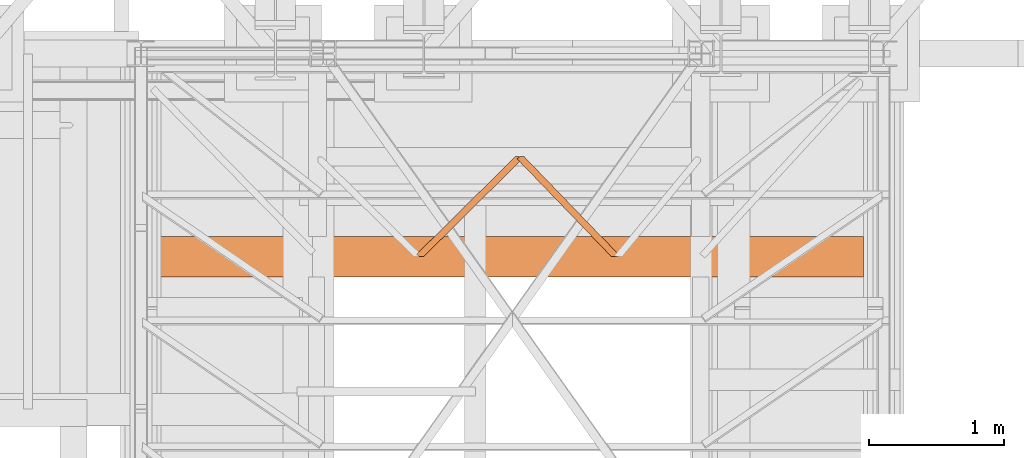
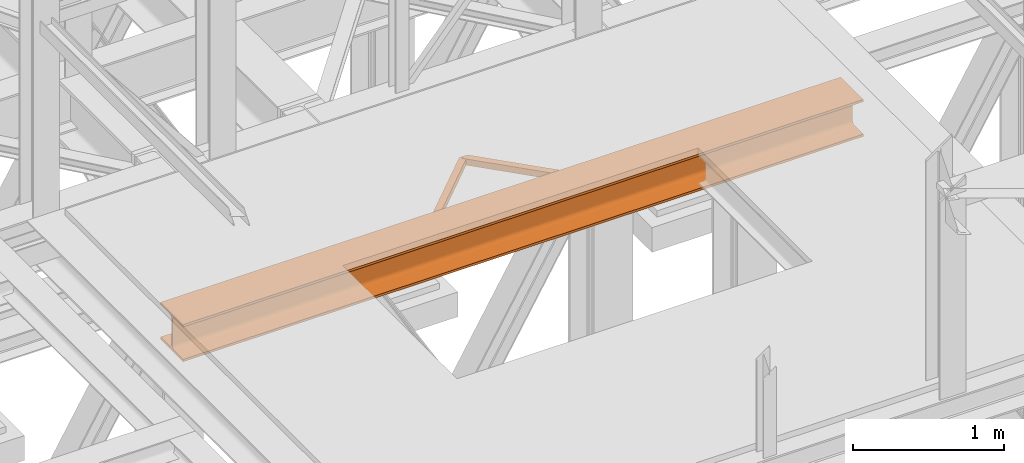
# One storey, part 68 of 208: 3 proxies.
"""IFC2X3 building model written with IfcOpenShell, lengths in millimetres."""

from ifc_helpers import new_model, entity, si_unit, converted_unit, frame, origin, origin_with_axes, place, context, subcontext, project, spatial, faceted_brep, element, save


model = new_model("IFC2X3")

# Units and contexts
model_context = context("Model", 3, precision=1e-05, world=origin())
plan_context = context("Plan", 3, precision=1e-05, world=origin())
body_context = subcontext(model_context, "Body", "Model", "MODEL_VIEW")
ifc_project = project(units=[si_unit("LENGTHUNIT", "METRE", prefix="MILLI"), converted_unit("PLANEANGLEUNIT", "DEGREE", entity("IfcPlaneAngleMeasure", 0.0174532925199433), si_unit("PLANEANGLEUNIT", "RADIAN"), dimensions=[0, 0, 0, 0, 0, 0, 0]), si_unit("AREAUNIT", "SQUARE_METRE"), si_unit("VOLUMEUNIT", "CUBIC_METRE")], contexts=[model_context, plan_context])

# Building, storey
building_placement = place(None, origin())
building = spatial("IfcBuilding", under=ifc_project, at=building_placement, CompositionType="COMPLEX")
storey_placement = place(building_placement, origin_with_axes())
storey = spatial("IfcBuildingStorey", under=building, at=storey_placement, Name="Geschoss", CompositionType="ELEMENT")

# Proxies
proxy_1_placement = place(storey_placement, frame((3238.199636538295, -18763.0743901279, 5124.989999999998), z_axis=(0.0, 0.0, 1.0), x_axis=(1.0, 0.0, 0.0)))
element("IfcBuildingElementProxy", 1, at=proxy_1_placement, inside=storey, context=body_context, shape_type="Brep", body=[
    faceted_brep([(733.6206372988609, 739.8100000473096, 0.01000000000021828), (733.6206372988618, 739.8100000473096, 50.01000000000022), (0.01000000000021828, 13.68593938003687, 50.01000000000022), (0.01000000000021828, 13.68593938003687, 0.01000000000021828), (759.638881951425, 739.8100000473096, 0.01000000000021828), (733.6206372988609, 739.8100000473096, 0.01000000000021828), (0.01000000000021828, 13.68593938003687, 0.01000000000021828), (18.38576148241555, 0.00999999999839929, 0.01000000000021828), (56.46338220809412, 0.00999999999839929, 0.01000000000021828), (784.8981974364888, 721.0110584260037, 0.01000000000021828), (784.8981974364888, 721.0110584260037, 0.01000000000021828), (56.46338220809412, 0.00999999999839929, 0.01000000000021828), (56.46338220809412, 0.00999999999839929, 50.01000000000022), (784.8981974364888, 721.0110584260037, 50.01000000000022), (784.8981974364888, 721.0110584260037, 50.01000000000022), (56.46338220809412, 0.00999999999839929, 50.01000000000022), (18.38576148241555, 0.00999999999839929, 50.01000000000022), (0.01000000000021828, 13.68593938003687, 50.01000000000022), (733.6206372988618, 739.8100000473096, 50.01000000000022), (759.638881951425, 739.8100000473096, 50.01000000000022), (759.638881951425, 739.8100000473096, 50.01000000000022), (759.6388819514259, 739.8100000473096, 46.01000000000022), (781.6893443484278, 723.3992087268089, 46.01000000000022), (781.6893443484278, 723.3992087268089, 4.010000000000218), (759.6388819514259, 739.8100000473096, 4.010000000000218), (759.638881951425, 739.8100000473096, 0.01000000000021828), (784.8981974364888, 721.0110584260037, 0.01000000000021828), (784.8981974364888, 721.0110584260037, 50.01000000000022), (0.01000000000021828, 13.68593938003687, 50.01000000000022), (18.38576148241555, 0.00999999999839929, 50.01000000000022), (18.38576148241555, 0.00999999999839929, 46.01000000000022), (3.218853088061223, 11.29778907923173, 46.01000000000022), (3.218853088061223, 11.29778907923173, 4.010000000000218), (18.38576148241555, 0.00999999999839929, 4.010000000000218), (18.38576148241555, 0.00999999999839929, 0.01000000000021828), (0.01000000000021828, 13.68593938003687, 0.01000000000021828), (739.2422632986627, 739.8100000473096, 46.01000000000022), (739.2422632986627, 739.8100000473096, 4.010000000000218), (3.218853088061223, 11.29778907923173, 4.010000000000218), (3.218853088061223, 11.29778907923173, 46.01000000000022), (739.2422632986627, 739.8100000473096, 4.010000000000218), (759.6388819514259, 739.8100000473096, 4.010000000000218), (781.6893443484278, 723.3992087268089, 4.010000000000218), (50.8417562082941, 0.00999999999839929, 4.010000000000218), (18.38576148241555, 0.00999999999839929, 4.010000000000218), (3.218853088061223, 11.29778907923173, 4.010000000000218), (781.6893443484278, 723.3992087268089, 4.010000000000218), (781.6893443484278, 723.3992087268089, 46.01000000000022), (50.84175620829319, 0.00999999999839929, 46.00999999999931), (50.8417562082941, 0.00999999999839929, 4.010000000000218), (781.6893443484278, 723.3992087268089, 46.01000000000022), (759.6388819514259, 739.8100000473096, 46.01000000000022), (739.2422632986627, 739.8100000473096, 46.01000000000022), (3.218853088061223, 11.29778907923173, 46.01000000000022), (18.38576148241555, 0.00999999999839929, 46.01000000000022), (50.84175620829319, 0.00999999999839929, 46.00999999999931), (56.46338220809412, 0.00999999999839929, 0.01000000000021828), (18.38576148241555, 0.00999999999839929, 0.01000000000021828), (18.38576148241555, 0.00999999999839929, 4.010000000000218), (50.8417562082941, 0.00999999999839929, 4.010000000000218), (50.84175620829319, 0.00999999999839929, 46.00999999999931), (18.38576148241555, 0.00999999999839929, 46.01000000000022), (18.38576148241555, 0.00999999999839929, 50.01000000000022), (56.46338220809412, 0.00999999999839929, 50.01000000000022), (733.6206372988618, 739.8100000473096, 50.01000000000022), (733.6206372988609, 739.8100000473096, 0.01000000000021828), (759.638881951425, 739.8100000473096, 0.01000000000021828), (759.6388819514259, 739.8100000473096, 4.010000000000218), (739.2422632986627, 739.8100000473096, 4.010000000000218), (739.2422632986627, 739.8100000473096, 46.01000000000022), (759.6388819514259, 739.8100000473096, 46.01000000000022), (759.638881951425, 739.8100000473096, 50.01000000000022)], [[[0, 1, 2, 3]], [[4, 5, 6, 7, 8, 9]], [[10, 11, 12, 13]], [[14, 15, 16, 17, 18, 19]], [[20, 21, 22, 23, 24, 25, 26, 27]], [[28, 29, 30, 31, 32, 33, 34, 35]], [[36, 37, 38, 39]], [[40, 41, 42, 43, 44, 45]], [[46, 47, 48, 49]], [[50, 51, 52, 53, 54, 55]], [[56, 57, 58, 59, 60, 61, 62, 63]], [[64, 65, 66, 67, 68, 69, 70, 71]]], orient=[[False], [False], [False], [False], [False], [False], [False], [False], [False], [False], [False], [False]]),
])
proxy_2_placement = place(storey_placement, frame((3982.977170374019, -18763.0743901279, 5124.989999999998), z_axis=(0.0, 0.0, 1.0), x_axis=(1.0, 0.0, 0.0)))
element("IfcBuildingElementProxy", 2, at=proxy_2_placement, inside=storey, context=body_context, shape_type="Brep", body=[
    faceted_brep([(50.79478130679308, 739.8100000473096, 50.01000000000022), (50.79478130679308, 739.8100000473096, 0.01000000000021828), (757.296978527831, 8.234371096019458, 0.01000000000021828), (757.296978527831, 8.234371096019458, 50.01000000000022), (50.79478130679308, 739.8100000473096, 0.01000000000021828), (25.269315485064, 739.8100000473096, 0.01000000000021828), (0.01000000000021828, 721.0110584260037, 0.01000000000021828), (696.3000509778785, 0.00999999999839929, 0.009999999999308784), (746.2462508663793, 0.00999999999839929, 0.01000000000021828), (757.296978527831, 8.234371096019458, 0.01000000000021828), (0.01000000000021828, 721.0110584260037, 0.01000000000021828), (0.01000000000021828, 721.0110584260037, 50.01000000000022), (696.3000509778785, 0.00999999999839929, 50.01000000000022), (696.3000509778785, 0.00999999999839929, 0.009999999999308784), (0.01000000000021828, 721.0110584260037, 50.01000000000022), (25.269315485064, 739.8100000473096, 50.01000000000022), (50.79478130679308, 739.8100000473096, 50.01000000000022), (757.296978527831, 8.234371096019458, 50.01000000000022), (746.2462508663793, 0.00999999999839929, 50.01000000000022), (696.3000509778785, 0.00999999999839929, 50.01000000000022), (25.269315485064, 739.8100000473096, 0.01000000000021828), (25.269315485064, 739.8100000473096, 4.010000000000218), (3.218853088061223, 723.3992087268089, 4.010000000000218), (3.218853088061223, 723.3992087268089, 46.01000000000022), (25.269315485064, 739.8100000473096, 46.01000000000022), (25.269315485064, 739.8100000473096, 50.01000000000022), (0.01000000000021828, 721.0110584260037, 50.01000000000022), (0.01000000000021828, 721.0110584260037, 0.01000000000021828), (757.296978527831, 8.234371096019458, 50.01000000000022), (757.296978527831, 8.234371096019458, 0.01000000000021828), (746.2462508663793, 0.00999999999839929, 0.01000000000021828), (746.2462508663793, 0.00999999999839929, 4.010000000000218), (754.08812543977, 5.846220795214322, 4.010000000000218), (754.08812543977, 5.846220795214322, 46.01000000000022), (746.2462508663793, 0.00999999999839929, 46.01000000000022), (746.2462508663793, 0.00999999999839929, 50.01000000000022), (45.27962745085006, 739.8100000473096, 4.010000000000218), (45.27962745085006, 739.8100000473096, 46.01000000000022), (754.08812543977, 5.846220795214322, 46.01000000000022), (754.08812543977, 5.846220795214322, 4.010000000000218), (25.269315485064, 739.8100000473096, 4.010000000000218), (45.27962745085006, 739.8100000473096, 4.010000000000218), (754.08812543977, 5.846220795214322, 4.010000000000218), (746.2462508663793, 0.00999999999839929, 4.010000000000218), (701.8152048338216, 0.00999999999839929, 4.010000000000218), (3.218853088061223, 723.3992087268089, 4.010000000000218), (3.218853088061223, 723.3992087268089, 4.010000000000218), (701.8152048338216, 0.00999999999839929, 4.010000000000218), (701.8152048338216, 0.00999999999839929, 46.01000000000022), (3.218853088061223, 723.3992087268089, 46.01000000000022), (3.218853088061223, 723.3992087268089, 46.01000000000022), (701.8152048338216, 0.00999999999839929, 46.01000000000022), (746.2462508663793, 0.00999999999839929, 46.01000000000022), (754.08812543977, 5.846220795214322, 46.01000000000022), (45.27962745085006, 739.8100000473096, 46.01000000000022), (25.269315485064, 739.8100000473096, 46.01000000000022), (746.2462508663793, 0.00999999999839929, 0.01000000000021828), (696.3000509778785, 0.00999999999839929, 0.009999999999308784), (696.3000509778785, 0.00999999999839929, 50.01000000000022), (746.2462508663793, 0.00999999999839929, 50.01000000000022), (746.2462508663793, 0.00999999999839929, 46.01000000000022), (701.8152048338216, 0.00999999999839929, 46.01000000000022), (701.8152048338216, 0.00999999999839929, 4.010000000000218), (746.2462508663793, 0.00999999999839929, 4.010000000000218), (50.79478130679308, 739.8100000473096, 0.01000000000021828), (50.79478130679308, 739.8100000473096, 50.01000000000022), (25.269315485064, 739.8100000473096, 50.01000000000022), (25.269315485064, 739.8100000473096, 46.01000000000022), (45.27962745085006, 739.8100000473096, 46.01000000000022), (45.27962745085006, 739.8100000473096, 4.010000000000218), (25.269315485064, 739.8100000473096, 4.010000000000218), (25.269315485064, 739.8100000473096, 0.01000000000021828)], [[[0, 1, 2, 3]], [[4, 5, 6, 7, 8, 9]], [[10, 11, 12, 13]], [[14, 15, 16, 17, 18, 19]], [[20, 21, 22, 23, 24, 25, 26, 27]], [[28, 29, 30, 31, 32, 33, 34, 35]], [[36, 37, 38, 39]], [[40, 41, 42, 43, 44, 45]], [[46, 47, 48, 49]], [[50, 51, 52, 53, 54, 55]], [[56, 57, 58, 59, 60, 61, 62, 63]], [[64, 65, 66, 67, 68, 69, 70, 71]]], orient=[[False], [False], [False], [False], [False], [False], [False], [False], [False], [False], [False], [False]]),
])
proxy_3_placement = place(storey_placement, frame((1343.254973297044, -18918.57439012789, 4984.990005364416), z_axis=(0.0, 0.0, 1.0), x_axis=(1.0, 0.0, 0.0)))
element("IfcBuildingElementProxy", 3, at=proxy_3_placement, inside=storey, context=body_context, shape_type="Brep", body=[
    faceted_brep([(0.01000000000203727, 0.00999999999839929, 300.0100000000002), (5205.009995231621, 0.00999999999839929, 300.0100000000002), (5205.009995231621, 0.00999999999839929, 281.0100000000002), (0.01000000000112777, 0.00999999999839929, 281.0100000000002), (0.01000000000112777, 0.00999999999839929, 281.0100000000002), (5205.009995231621, 0.00999999999839929, 281.0100000000002), (5205.009995231621, 117.5099999999984, 281.0100000000002), (0.01000000000112777, 117.5099999999984, 281.0100000000002), (0.01000000000112777, 117.5099999999984, 281.0100000000002), (5205.009995231621, 117.5099999999984, 281.0100000000002), (5205.009995231621, 124.4980907807731, 280.0899181875066), (0.01000000000112777, 124.4980907807731, 280.0899181875066), (0.01000000000112777, 124.4980907807731, 280.0899181875066), (5205.009995231621, 124.4980907807731, 280.0899181875066), (5205.009995231621, 131.0099606245385, 277.3926133818113), (0.01000000000021828, 131.0099606245385, 277.3926133818113), (0.01000000000021828, 131.0099606245385, 277.3926133818113), (5205.009995231621, 131.0099606245385, 277.3926133818113), (5205.009995231621, 136.6018830920366, 273.1018830920375), (0.01000000000112777, 136.6018830920366, 273.1018830920366), (0.01000000000112777, 136.6018830920366, 273.1018830920366), (5205.009995231621, 136.6018830920366, 273.1018830920375), (5205.009995231621, 140.8926133818095, 267.5099606245422), (0.01000000000203727, 140.8926133818095, 267.5099606245422), (0.01000000000203727, 140.8926133818095, 267.5099606245422), (5205.009995231621, 140.8926133818095, 267.5099606245422), (5205.009995231621, 143.5899181875029, 260.9980907807767), (0.01000000000203727, 143.5899181875029, 260.9980907807767), (0.01000000000203727, 143.5899181875029, 260.9980907807767), (5205.009995231621, 143.5899181875029, 260.9980907807767), (5205.009995231621, 144.5099999999984, 254.0100000000002), (0.01000000000203727, 144.5099999999984, 254.0100000000002), (0.01000000000203727, 144.5099999999984, 254.0100000000002), (5205.009995231621, 144.5099999999984, 254.0100000000002), (5205.009995231621, 144.5099999999984, 46.01000000000022), (0.01000000000112777, 144.5099999999984, 46.01000000000022), (0.01000000000112777, 144.5099999999984, 46.01000000000022), (5205.009995231621, 144.5099999999984, 46.01000000000022), (5205.009995231621, 143.1884339422577, 37.66656945413888), (0.01000000000112777, 143.1884339422577, 37.66656945413979), (0.01000000000112777, 143.1884339422577, 37.66656945413979), (5205.009995231621, 143.1884339422577, 37.66656945413888), (5205.009995231621, 139.3534254633996, 30.13982493419917), (0.01000000000112777, 139.3534254633996, 30.13982493419826), (0.01000000000112777, 139.3534254633996, 30.13982493419826), (5205.009995231621, 139.3534254633996, 30.13982493419917), (5205.009995231621, 133.3801750657985, 24.16657453659809), (0.01000000000203727, 133.3801750657985, 24.16657453659809), (0.01000000000203727, 133.3801750657985, 24.16657453659809), (5205.009995231621, 133.3801750657985, 24.16657453659809), (5205.009995231621, 125.8534305458597, 20.33156605774093), (0.01000000000112777, 125.8534305458597, 20.33156605774093), (0.01000000000112777, 125.8534305458597, 20.33156605774093), (5205.009995231621, 125.8534305458597, 20.33156605774093), (5205.009995231621, 117.5099999999984, 19.01000000000022), (0.01000000000112777, 117.5099999999984, 19.01000000000022), (0.01000000000112777, 117.5099999999984, 19.01000000000022), (5205.009995231621, 117.5099999999984, 19.01000000000022), (5205.009995231621, 0.00999999999839929, 19.01000000000022), (0.01000000000203727, 0.00999999999839929, 19.01000000000022), (0.01000000000203727, 0.00999999999839929, 19.01000000000022), (5205.009995231621, 0.00999999999839929, 19.01000000000022), (5205.009995231621, 0.00999999999839929, 0.01000000000021828), (0.01000000000112777, 0.00999999999839929, 0.01000000000021828), (0.01000000000112777, 0.00999999999839929, 0.01000000000021828), (5205.009995231621, 0.00999999999839929, 0.01000000000021828), (5205.009995231621, 300.0099999999984, 0.01000000000021828), (0.01000000000021828, 300.0099999999984, 0.01000000000021828), (0.01000000000021828, 300.0099999999984, 0.01000000000021828), (5205.009995231621, 300.0099999999984, 0.01000000000021828), (5205.009995231621, 300.0099999999984, 19.01000000000022), (0.01000000000203727, 300.0099999999984, 19.01000000000022), (0.01000000000203727, 300.0099999999984, 19.01000000000022), (5205.009995231621, 300.0099999999984, 19.01000000000022), (5205.009995231621, 182.5099999999984, 19.01000000000022), (0.01000000000203727, 182.5099999999984, 19.01000000000022), (0.01000000000203727, 182.5099999999984, 19.01000000000022), (5205.009995231621, 182.5099999999984, 19.01000000000022), (5205.009995231621, 174.1665694541371, 20.33156605774093), (0.01000000000112777, 174.1665694541371, 20.33156605774093), (0.01000000000112777, 174.1665694541371, 20.33156605774093), (5205.009995231621, 174.1665694541371, 20.33156605774093), (5205.009995231621, 166.6398249341983, 24.16657453659809), (0.01000000000203727, 166.6398249341983, 24.16657453659809), (0.01000000000203727, 166.6398249341983, 24.16657453659809), (5205.009995231621, 166.6398249341983, 24.16657453659809), (5205.009995231621, 160.6665745365972, 30.13982493419917), (0.01000000000112777, 160.6665745365972, 30.13982493419826), (0.01000000000112777, 160.6665745365972, 30.13982493419826), (5205.009995231621, 160.6665745365972, 30.13982493419917), (5205.009995231621, 156.8315660577391, 37.66656945413888), (0.01000000000112777, 156.8315660577391, 37.66656945413888), (0.01000000000112777, 156.8315660577391, 37.66656945413888), (5205.009995231621, 156.8315660577391, 37.66656945413888), (5205.009995231621, 155.5099999999984, 46.01000000000022), (0.01000000000112777, 155.5099999999984, 46.01000000000022), (0.01000000000112777, 155.5099999999984, 46.01000000000022), (5205.009995231621, 155.5099999999984, 46.01000000000022), (5205.009995231621, 155.5099999999984, 254.0100000000002), (0.01000000000021828, 155.5099999999984, 254.0100000000002), (0.01000000000021828, 155.5099999999984, 254.0100000000002), (5205.009995231621, 155.5099999999984, 254.0100000000002), (5205.009995231621, 156.8315660577391, 262.3534305458607), (0.01000000000021828, 156.8315660577391, 262.3534305458607), (0.01000000000021828, 156.8315660577391, 262.3534305458607), (5205.009995231621, 156.8315660577391, 262.3534305458607), (5205.009995231621, 160.6665745365972, 269.8801750658022), (0.01000000000021828, 160.6665745365972, 269.8801750658022), (0.01000000000021828, 160.6665745365972, 269.8801750658022), (5205.009995231621, 160.6665745365972, 269.8801750658022), (5205.009995231621, 166.6398249341983, 275.8534254634024), (0.01000000000021828, 166.6398249341983, 275.8534254634024), (0.01000000000021828, 166.6398249341983, 275.8534254634024), (5205.009995231621, 166.6398249341983, 275.8534254634024), (5205.009995231621, 174.1665694541371, 279.6884339422595), (0.01000000000112777, 174.1665694541371, 279.6884339422595), (0.01000000000112777, 174.1665694541371, 279.6884339422595), (5205.009995231621, 174.1665694541371, 279.6884339422595), (5205.009995231621, 182.5099999999984, 281.0100000000002), (0.01000000000112777, 182.5099999999984, 281.0100000000002), (0.01000000000112777, 182.5099999999984, 281.0100000000002), (5205.009995231621, 182.5099999999984, 281.0100000000002), (5205.009995231621, 300.0099999999984, 281.0100000000002), (0.01000000000112777, 300.0099999999984, 281.0100000000002), (0.01000000000112777, 300.0099999999984, 281.0100000000002), (5205.009995231621, 300.0099999999984, 281.0100000000002), (5205.009995231621, 300.0099999999984, 300.0100000000002), (0.01000000000203727, 300.0099999999984, 300.0100000000002), (0.01000000000203727, 300.0099999999984, 300.0100000000002), (5205.009995231621, 300.0099999999984, 300.0100000000002), (5205.009995231621, 0.00999999999839929, 300.0100000000002), (0.01000000000203727, 0.00999999999839929, 300.0100000000002), (5205.009995231621, 0.00999999999839929, 300.0100000000002), (5205.009995231621, 300.0099999999984, 300.0100000000002), (5205.009995231621, 300.0099999999984, 281.0100000000002), (5205.009995231621, 182.5099999999984, 281.0100000000002), (5205.009995231621, 174.1665694541371, 279.6884339422595), (5205.009995231621, 166.6398249341983, 275.8534254634024), (5205.009995231621, 160.6665745365972, 269.8801750658022), (5205.009995231621, 156.8315660577391, 262.3534305458607), (5205.009995231621, 155.5099999999984, 254.0100000000002), (5205.009995231621, 155.5099999999984, 46.01000000000022), (5205.009995231621, 156.8315660577391, 37.66656945413888), (5205.009995231621, 160.6665745365972, 30.13982493419917), (5205.009995231621, 166.6398249341983, 24.16657453659809), (5205.009995231621, 174.1665694541371, 20.33156605774093), (5205.009995231621, 182.5099999999984, 19.01000000000022), (5205.009995231621, 300.0099999999984, 19.01000000000022), (5205.009995231621, 300.0099999999984, 0.01000000000021828), (5205.009995231621, 0.00999999999839929, 0.01000000000021828), (5205.009995231621, 0.00999999999839929, 19.01000000000022), (5205.009995231621, 117.5099999999984, 19.01000000000022), (5205.009995231621, 125.8534305458597, 20.33156605774093), (5205.009995231621, 133.3801750657985, 24.16657453659809), (5205.009995231621, 139.3534254633996, 30.13982493419917), (5205.009995231621, 143.1884339422577, 37.66656945413888), (5205.009995231621, 144.5099999999984, 46.01000000000022), (5205.009995231621, 144.5099999999984, 254.0100000000002), (5205.009995231621, 143.5899181875029, 260.9980907807767), (5205.009995231621, 140.8926133818095, 267.5099606245422), (5205.009995231621, 136.6018830920366, 273.1018830920375), (5205.009995231621, 131.0099606245385, 277.3926133818113), (5205.009995231621, 124.4980907807731, 280.0899181875066), (5205.009995231621, 117.5099999999984, 281.0100000000002), (5205.009995231621, 0.00999999999839929, 281.0100000000002), (0.01000000000112777, 0.00999999999839929, 281.0100000000002), (0.01000000000112777, 117.5099999999984, 281.0100000000002), (0.01000000000112777, 124.4980907807731, 280.0899181875066), (0.01000000000021828, 131.0099606245385, 277.3926133818113), (0.01000000000112777, 136.6018830920366, 273.1018830920366), (0.01000000000203727, 140.8926133818095, 267.5099606245422), (0.01000000000203727, 143.5899181875029, 260.9980907807767), (0.01000000000203727, 144.5099999999984, 254.0100000000002), (0.01000000000112777, 144.5099999999984, 46.01000000000022), (0.01000000000112777, 143.1884339422577, 37.66656945413979), (0.01000000000112777, 139.3534254633996, 30.13982493419826), (0.01000000000203727, 133.3801750657985, 24.16657453659809), (0.01000000000112777, 125.8534305458597, 20.33156605774093), (0.01000000000112777, 117.5099999999984, 19.01000000000022), (0.01000000000203727, 0.00999999999839929, 19.01000000000022), (0.01000000000112777, 0.00999999999839929, 0.01000000000021828), (0.01000000000021828, 300.0099999999984, 0.01000000000021828), (0.01000000000203727, 300.0099999999984, 19.01000000000022), (0.01000000000203727, 182.5099999999984, 19.01000000000022), (0.01000000000112777, 174.1665694541371, 20.33156605774093), (0.01000000000203727, 166.6398249341983, 24.16657453659809), (0.01000000000112777, 160.6665745365972, 30.13982493419826), (0.01000000000112777, 156.8315660577391, 37.66656945413888), (0.01000000000112777, 155.5099999999984, 46.01000000000022), (0.01000000000021828, 155.5099999999984, 254.0100000000002), (0.01000000000021828, 156.8315660577391, 262.3534305458607), (0.01000000000021828, 160.6665745365972, 269.8801750658022), (0.01000000000021828, 166.6398249341983, 275.8534254634024), (0.01000000000112777, 174.1665694541371, 279.6884339422595), (0.01000000000112777, 182.5099999999984, 281.0100000000002), (0.01000000000112777, 300.0099999999984, 281.0100000000002), (0.01000000000203727, 300.0099999999984, 300.0100000000002), (0.01000000000203727, 0.00999999999839929, 300.0100000000002)], [[[0, 1, 2, 3]], [[4, 5, 6, 7]], [[8, 9, 10, 11]], [[12, 13, 14, 15]], [[16, 17, 18, 19]], [[20, 21, 22, 23]], [[24, 25, 26, 27]], [[28, 29, 30, 31]], [[32, 33, 34, 35]], [[36, 37, 38, 39]], [[40, 41, 42, 43]], [[44, 45, 46, 47]], [[48, 49, 50, 51]], [[52, 53, 54, 55]], [[56, 57, 58, 59]], [[60, 61, 62, 63]], [[64, 65, 66, 67]], [[68, 69, 70, 71]], [[72, 73, 74, 75]], [[76, 77, 78, 79]], [[80, 81, 82, 83]], [[84, 85, 86, 87]], [[88, 89, 90, 91]], [[92, 93, 94, 95]], [[96, 97, 98, 99]], [[100, 101, 102, 103]], [[104, 105, 106, 107]], [[108, 109, 110, 111]], [[112, 113, 114, 115]], [[116, 117, 118, 119]], [[120, 121, 122, 123]], [[124, 125, 126, 127]], [[128, 129, 130, 131]], [[132, 133, 134, 135, 136, 137, 138, 139, 140, 141, 142, 143, 144, 145, 146, 147, 148, 149, 150, 151, 152, 153, 154, 155, 156, 157, 158, 159, 160, 161, 162, 163, 164]], [[165, 166, 167, 168, 169, 170, 171, 172, 173, 174, 175, 176, 177, 178, 179, 180, 181, 182, 183, 184, 185, 186, 187, 188, 189, 190, 191, 192, 193, 194, 195, 196, 197]]], orient=[[False], [False], [False], [False], [False], [False], [False], [False], [False], [False], [False], [False], [False], [False], [False], [False], [False], [False], [False], [False], [False], [False], [False], [False], [False], [False], [False], [False], [False], [False], [False], [False], [False], [False], [False]]),
])

save(model, "model.ifc")
